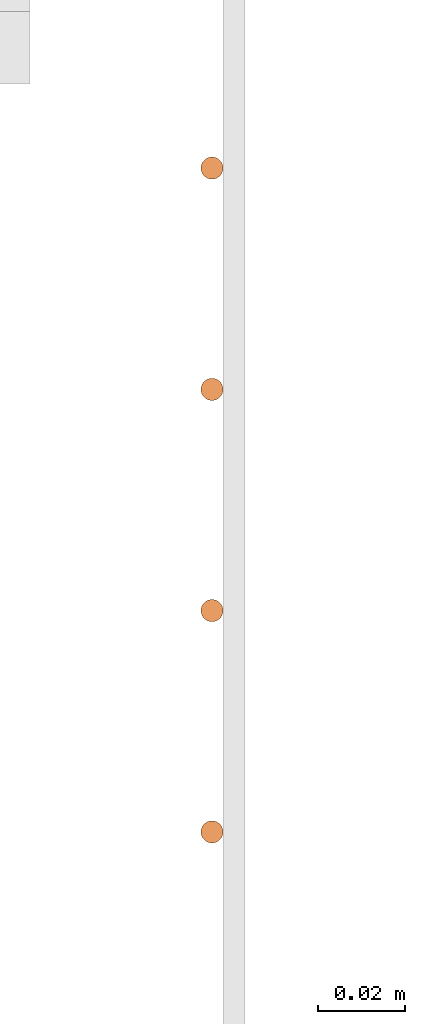
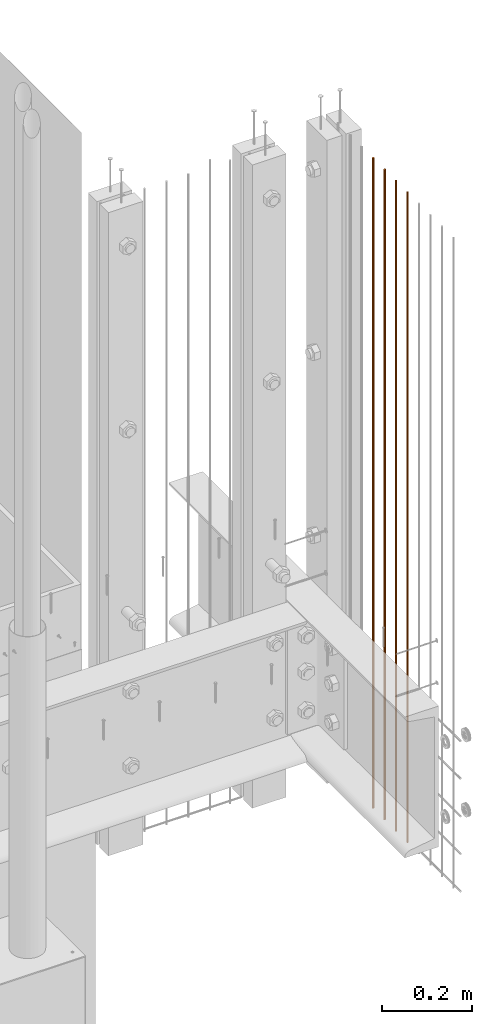
# One storey, part 15 of 44: 4 proxies.
"""IFC4 building model written with IfcOpenShell, lengths in feet."""

from ifc_helpers import new_model, entity, si_unit, converted_unit, derived_unit, direction, frame, origin, origin_2d_with_axis, place, context, subcontext, project, spatial, circle, extrude, source, transform, mapped, material, type_object, type_shapes, element, save


model = new_model("IFC4")

# Units and contexts
model_context = context("Model", 3, precision=0.0001, world=origin(), true_north=direction((6.12303176911189e-17, 1.0)))
body_context = subcontext(model_context, "Body", "Model", "MODEL_VIEW")
ifc_project = project(units=[converted_unit("LENGTHUNIT", "FOOT", entity("IfcRatioMeasure", 0.3048), si_unit("LENGTHUNIT", "METRE"), dimensions=[1, 0, 0, 0, 0, 0, 0]), converted_unit("AREAUNIT", "SQUARE FOOT", entity("IfcRatioMeasure", 0.09290304), si_unit("AREAUNIT", "SQUARE_METRE"), dimensions=[2, 0, 0, 0, 0, 0, 0]), converted_unit("VOLUMEUNIT", "CUBIC FOOT", entity("IfcRatioMeasure", 0.028316846592), si_unit("VOLUMEUNIT", "CUBIC_METRE"), dimensions=[3, 0, 0, 0, 0, 0, 0]), converted_unit("PLANEANGLEUNIT", "DEGREE", entity("IfcRatioMeasure", 0.0174532925199433), si_unit("PLANEANGLEUNIT", "RADIAN"), dimensions=[0, 0, 0, 0, 0, 0, 0]), si_unit("MASSUNIT", "GRAM", prefix="KILO"), derived_unit("MASSDENSITYUNIT", [(si_unit("MASSUNIT", "GRAM", prefix="KILO"), 1), (si_unit("LENGTHUNIT", "METRE"), -3)]), derived_unit("MOMENTOFINERTIAUNIT", [(si_unit("LENGTHUNIT", "METRE"), 4)]), si_unit("TIMEUNIT", "SECOND"), si_unit("FREQUENCYUNIT", "HERTZ"), si_unit("THERMODYNAMICTEMPERATUREUNIT", "DEGREE_CELSIUS"), derived_unit("THERMALTRANSMITTANCEUNIT", [(si_unit("MASSUNIT", "GRAM", prefix="KILO"), 1), (si_unit("THERMODYNAMICTEMPERATUREUNIT", "KELVIN"), -1), (si_unit("TIMEUNIT", "SECOND"), -3)]), derived_unit("VOLUMETRICFLOWRATEUNIT", [(si_unit("LENGTHUNIT", "METRE"), 3), (si_unit("TIMEUNIT", "SECOND"), -1)]), si_unit("ELECTRICCURRENTUNIT", "AMPERE"), si_unit("ELECTRICVOLTAGEUNIT", "VOLT"), si_unit("POWERUNIT", "WATT"), si_unit("FORCEUNIT", "NEWTON"), si_unit("ILLUMINANCEUNIT", "LUX"), si_unit("LUMINOUSFLUXUNIT", "LUMEN"), si_unit("LUMINOUSINTENSITYUNIT", "CANDELA"), derived_unit("USERDEFINED", [(si_unit("MASSUNIT", "GRAM", prefix="KILO"), -1), (si_unit("LENGTHUNIT", "METRE"), -2), (si_unit("TIMEUNIT", "SECOND"), 3), (si_unit("LUMINOUSFLUXUNIT", "LUMEN"), 1)]), derived_unit("LINEARVELOCITYUNIT", [(si_unit("LENGTHUNIT", "METRE"), 1), (si_unit("TIMEUNIT", "SECOND"), -1)]), si_unit("PRESSUREUNIT", "PASCAL"), derived_unit("USERDEFINED", [(si_unit("LENGTHUNIT", "METRE"), -2), (si_unit("MASSUNIT", "GRAM", prefix="KILO"), 1), (si_unit("TIMEUNIT", "SECOND"), -2)]), derived_unit("LINEARFORCEUNIT", [(si_unit("MASSUNIT", "GRAM", prefix="KILO"), 1), (si_unit("LENGTHUNIT", "METRE"), 1), (si_unit("TIMEUNIT", "SECOND"), -2), (si_unit("LENGTHUNIT", "METRE"), -1)]), derived_unit("PLANARFORCEUNIT", [(si_unit("MASSUNIT", "GRAM", prefix="KILO"), 1), (si_unit("LENGTHUNIT", "METRE"), 1), (si_unit("TIMEUNIT", "SECOND"), -2), (si_unit("LENGTHUNIT", "METRE"), -2)])], contexts=[model_context])

# Site, building, storey
site_placement = place(None, origin())
site = spatial("IfcSite", under=ifc_project, at=site_placement, CompositionType="ELEMENT")
building_placement = place(site_placement, origin())
building = spatial("IfcBuilding", under=site, at=building_placement, CompositionType="ELEMENT")
storey_placement = place(building_placement, origin())
storey = spatial("IfcBuildingStorey", under=building, at=storey_placement, CompositionType="ELEMENT", Elevation=0.0)

# Proxies
ifc_material = material(Category="Materials")
building_element_proxy_type_1 = type_object("IfcBuildingElementProxyType", Name="RAILING 49:RAILING 20", PredefinedType="NOTDEFINED", material=ifc_material)
shared_shape_1 = source(origin(), body_context, "Body", "SweptSolid", [
    extrude(circle(Radius=0.00833333333333333, at=origin_2d_with_axis()), frame((0.013567166128496, 0.0135671661283334, 0.0)), (0.0, 0.0, 1.0), 5.77083333333334),
])
type_shapes(building_element_proxy_type_1, [shared_shape_1])
proxy_1_placement = place(storey_placement, frame((1494.4664034641, 4.30834400538705, 8.17708333333333)))
element("IfcBuildingElementProxy", 1, at=proxy_1_placement, inside=storey, type_object=building_element_proxy_type_1, material=ifc_material, Name="RAILING 49:RAILING 20", ObjectType="RAILING 49:RAILING 20", PredefinedType="NOTDEFINED", context=body_context, shape_type="MappedRepresentation", body=[
    mapped(shared_shape_1, transform((0.0, 0.0, 0.0), scale=1.0)),
])
building_element_proxy_type_2 = type_object("IfcBuildingElementProxyType", Name="RAILING 51:RAILING 20", PredefinedType="NOTDEFINED", material=ifc_material)
shared_shape_2 = source(origin(), body_context, "Body", "SweptSolid", [
    extrude(circle(Radius=0.00833333333333333, at=origin_2d_with_axis()), frame((0.013567166128496, 0.0135671661283334, 0.0)), (0.0, 0.0, 1.0), 5.77083333333334),
])
type_shapes(building_element_proxy_type_2, [shared_shape_2])
proxy_2_placement = place(storey_placement, frame((1494.4664034641, 4.14167733872039, 8.17708333333333)))
element("IfcBuildingElementProxy", 2, at=proxy_2_placement, inside=storey, type_object=building_element_proxy_type_2, material=ifc_material, Name="RAILING 51:RAILING 20", ObjectType="RAILING 51:RAILING 20", PredefinedType="NOTDEFINED", context=body_context, shape_type="MappedRepresentation", body=[
    mapped(shared_shape_2, transform((0.0, 0.0, 0.0), scale=1.0)),
])
building_element_proxy_type_3 = type_object("IfcBuildingElementProxyType", Name="RAILING 52:RAILING 20", PredefinedType="NOTDEFINED", material=ifc_material)
shared_shape_3 = source(origin(), body_context, "Body", "SweptSolid", [
    extrude(circle(Radius=0.00833333333333333, at=origin_2d_with_axis()), frame((0.013567166128496, 0.0135671661283334, 0.0)), (0.0, 0.0, 1.0), 5.77083333333334),
])
type_shapes(building_element_proxy_type_3, [shared_shape_3])
proxy_3_placement = place(storey_placement, frame((1494.4664034641, 3.97501067205372, 8.17708333333333)))
element("IfcBuildingElementProxy", 3, at=proxy_3_placement, inside=storey, type_object=building_element_proxy_type_3, material=ifc_material, Name="RAILING 52:RAILING 20", ObjectType="RAILING 52:RAILING 20", PredefinedType="NOTDEFINED", context=body_context, shape_type="MappedRepresentation", body=[
    mapped(shared_shape_3, transform((0.0, 0.0, 0.0), scale=1.0)),
])
building_element_proxy_type_4 = type_object("IfcBuildingElementProxyType", Name="RAILING 53:RAILING 20", PredefinedType="NOTDEFINED", material=ifc_material)
shared_shape_4 = source(origin(), body_context, "Body", "SweptSolid", [
    extrude(circle(Radius=0.00833333333333333, at=origin_2d_with_axis()), frame((0.013567166128496, 0.0135671661283334, 0.0)), (0.0, 0.0, 1.0), 5.77083333333334),
])
type_shapes(building_element_proxy_type_4, [shared_shape_4])
proxy_4_placement = place(storey_placement, frame((1494.4664034641, 3.80834400538705, 8.17708333333333)))
element("IfcBuildingElementProxy", 4, at=proxy_4_placement, inside=storey, type_object=building_element_proxy_type_4, material=ifc_material, Name="RAILING 53:RAILING 20", ObjectType="RAILING 53:RAILING 20", PredefinedType="NOTDEFINED", context=body_context, shape_type="MappedRepresentation", body=[
    mapped(shared_shape_4, transform((0.0, 0.0, 0.0), scale=1.0)),
])

save(model, "model.ifc")
